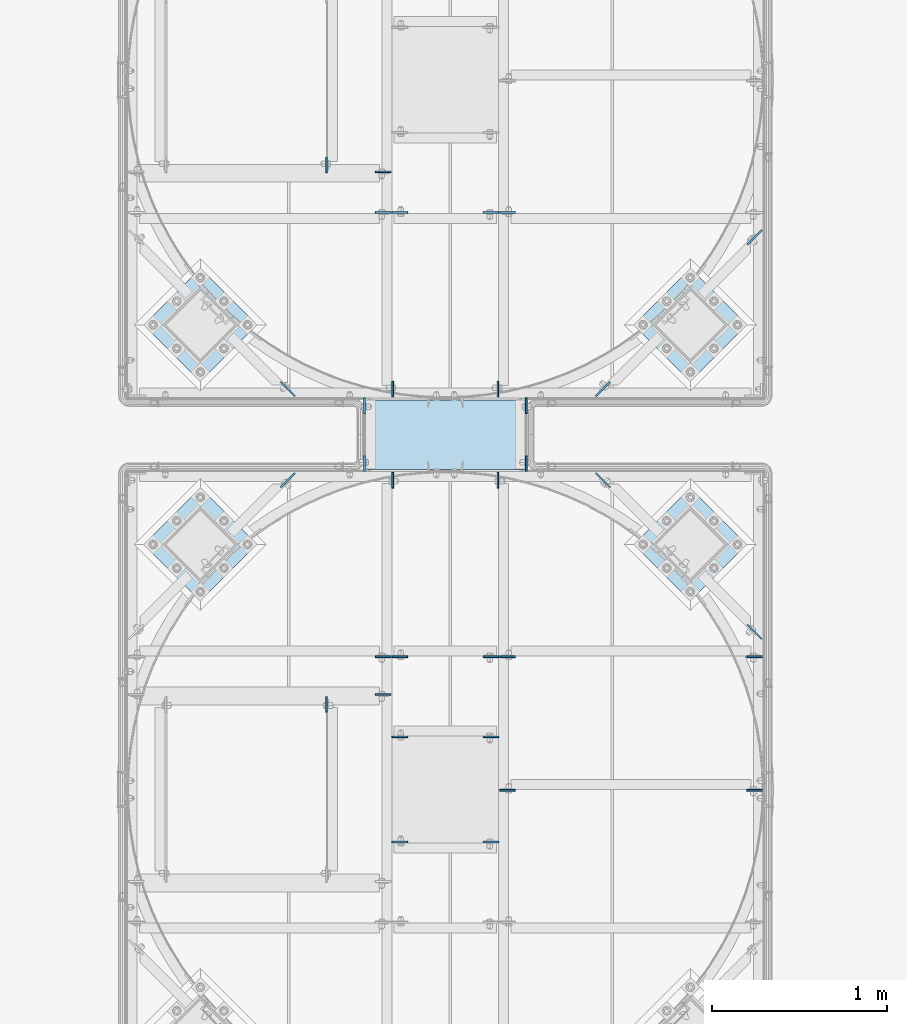
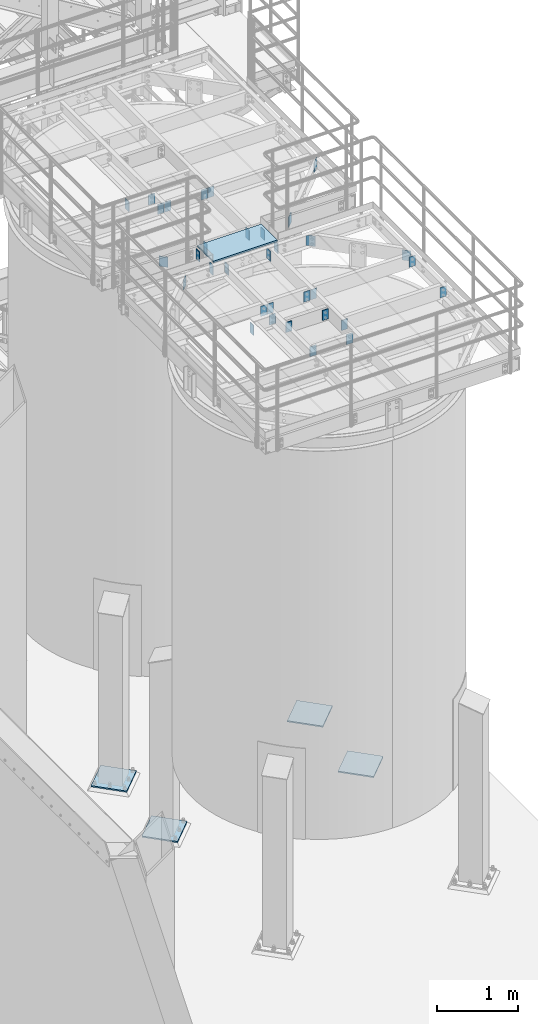
# One storey, part 1417 of 1876: 38 plates, 15 elements without a shape of their own.
"""IFC2X3 building model written with IfcOpenShell, lengths in millimetres."""

from ifc_helpers import new_model, si_unit, frame, origin_with_axes, place, context, subcontext, project, spatial, faceted_brep, material, type_object, element, aggregate, save


model = new_model("IFC2X3")

# Units and contexts
model_context = context("Model", 3, precision=1e-05, world=origin_with_axes())
body_context = subcontext(model_context, "Body", "Model", "MODEL_VIEW")
ifc_project = project(units=[si_unit("LENGTHUNIT", "METRE", prefix="MILLI"), si_unit("AREAUNIT", "SQUARE_METRE"), si_unit("VOLUMEUNIT", "CUBIC_METRE"), si_unit("MASSUNIT", "GRAM", prefix="KILO"), si_unit("TIMEUNIT", "SECOND"), si_unit("PLANEANGLEUNIT", "RADIAN"), si_unit("SOLIDANGLEUNIT", "STERADIAN"), si_unit("THERMODYNAMICTEMPERATUREUNIT", "DEGREE_CELSIUS"), si_unit("LUMINOUSINTENSITYUNIT", "LUMEN")], contexts=[model_context])

# Site, building, storey
site_placement = place(None, origin_with_axes())
site = spatial("IfcSite", under=ifc_project, at=site_placement, CompositionType="ELEMENT")
building_placement = place(site_placement, origin_with_axes())
building = spatial("IfcBuilding", under=site, at=building_placement, Name="Undefined", CompositionType="ELEMENT")
storey_placement = place(building_placement, origin_with_axes())
storey = spatial("IfcBuildingStorey", under=building, at=storey_placement, Name="Undefined", CompositionType="ELEMENT", Elevation=0.0)

# Assembly, plate
assembly_1_placement = place(storey_placement, origin_with_axes())
assembly_1 = element("IfcElementAssembly", 1, at=assembly_1_placement, inside=storey, Name="GRATING", AssemblyPlace="NOTDEFINED", PredefinedType="NOTDEFINED")
ifc_material_1 = material(Name="1")
plate_type_1 = type_object("IfcPlateType", PredefinedType="NOTDEFINED")
plate_1_placement = place(assembly_1_placement, frame((4730.75143150122, -11364.8204711914, 8010.525), z_axis=(1.0, 0.0, 0.0), x_axis=(0.0, -1.0, 0.0)))
plate_1 = element("IfcPlate", 2, at=plate_1_placement, type_object=plate_type_1, material=ifc_material_1, Name="GRATING", context=body_context, shape_type="Brep", body=[
    faceted_brep([(0.0, -12.6999999999998, 0.0), (1.80338247446343e-06, -12.6999999999998, 909.637512207031), (1.80338247446343e-06, 12.6999999999998, 909.637512207031), (0.0, 12.6999999999998, 0.0), (396.931427001953, -12.6999999999998, 909.637512207031), (396.931427001953, 12.6999999999998, 909.637512207031), (396.8720703125, -12.6999999999998, 0.0), (396.8720703125, 12.6999999999998, 0.0)], [[[0, 1, 2, 3]], [[1, 4, 5, 2]], [[4, 6, 7, 5]], [[6, 0, 3, 7]], [[5, 7, 3, 2]], [[6, 4, 1, 0]]]),
])
aggregate(assembly_1, [plate_1])

# Assembly, plates
assembly_2_placement = place(storey_placement, origin_with_axes())
assembly_2 = element("IfcElementAssembly", 3, at=assembly_2_placement, inside=storey, Name="BEAM", AssemblyPlace="NOTDEFINED", PredefinedType="RIGID_FRAME")
ifc_material_2 = material(Name="STEEL/A36")
plate_type_2 = type_object("IfcPlateType", PredefinedType="NOTDEFINED")
plate_2_placement = place(assembly_2_placement, frame((5643.56393150122, -11772.8644531238, 7972.425), z_axis=(0.0, 1.0, 0.0), x_axis=(0.0, 0.0, -1.0)))
plate_2 = element("IfcPlate", 4, at=plate_2_placement, type_object=plate_type_2, material=ifc_material_2, Name="PLATE", context=body_context, shape_type="Brep", body=[
    faceted_brep([(0.0, -4.76249999999982, 0.0), (0.0, -4.76249999999982, 88.9000015258789), (0.0, 4.76249999999982, 88.9000015258789), (0.0, 4.76249999999982, 0.0), (152.399993896484, -4.76249999999982, 88.9000015258789), (152.399993896484, 4.76249999999982, 88.9000015258789), (152.399993896484, -4.76249999999982, 0.0), (152.399993896484, 4.76249999999982, 0.0)], [[[0, 1, 2, 3]], [[1, 4, 5, 2]], [[4, 6, 7, 5]], [[6, 0, 3, 7]], [[5, 7, 3, 2]], [[6, 4, 1, 0]]]),
])
plate_3_placement = place(assembly_2_placement, frame((4719.63893150122, -11772.8644531238, 7972.425), z_axis=(0.0, 1.0, 0.0), x_axis=(0.0, 0.0, -1.0)))
plate_3 = element("IfcPlate", 5, at=plate_3_placement, type_object=plate_type_2, material=ifc_material_2, Name="PLATE", context=body_context, shape_type="Brep", body=[
    faceted_brep([(0.0, -4.76249999999982, 0.0), (0.0, -4.76249999999982, 88.9000015258789), (0.0, 4.76249999999982, 88.9000015258789), (0.0, 4.76249999999982, 0.0), (152.399993896484, -4.76249999999982, 88.9000015258789), (152.399993896484, 4.76249999999982, 88.9000015258789), (152.399993896484, -4.76249999999982, 0.0), (152.399993896484, 4.76249999999982, 0.0)], [[[0, 1, 2, 3]], [[1, 4, 5, 2]], [[4, 6, 7, 5]], [[6, 0, 3, 7]], [[5, 7, 3, 2]], [[6, 4, 1, 0]]]),
])

assembly_3_placement = place(storey_placement, origin_with_axes())
assembly_3 = element("IfcElementAssembly", 6, at=assembly_3_placement, inside=storey, Name="BEAM", AssemblyPlace="NOTDEFINED", PredefinedType="RIGID_FRAME")
plate_4_placement = place(assembly_3_placement, frame((4719.63893150122, -11353.7643554687, 7972.425), z_axis=(0.0, -1.0, 0.0), x_axis=(0.0, 0.0, -1.0)))
plate_4 = element("IfcPlate", 7, at=plate_4_placement, type_object=plate_type_2, material=ifc_material_2, Name="PLATE", context=body_context, shape_type="Brep", body=[
    faceted_brep([(0.0, -4.76249999999982, 0.0), (0.0, -4.76249999999982, 88.9000015258789), (0.0, 4.76249999999982, 88.9000015258789), (0.0, 4.76249999999982, 0.0), (152.399993896484, -4.76249999999982, 88.9000015258789), (152.399993896484, 4.76249999999982, 88.9000015258789), (152.399993896484, -4.76249999999982, 0.0), (152.399993896484, 4.76249999999982, 0.0)], [[[0, 1, 2, 3]], [[1, 4, 5, 2]], [[4, 6, 7, 5]], [[6, 0, 3, 7]], [[5, 7, 3, 2]], [[6, 4, 1, 0]]]),
])
plate_5_placement = place(assembly_3_placement, frame((5643.56393150122, -11353.7643554687, 7972.425), z_axis=(0.0, -1.0, 0.0), x_axis=(0.0, 0.0, -1.0)))
plate_5 = element("IfcPlate", 8, at=plate_5_placement, type_object=plate_type_2, material=ifc_material_2, Name="PLATE", context=body_context, shape_type="Brep", body=[
    faceted_brep([(0.0, -4.76249999999982, 0.0), (0.0, -4.76249999999982, 88.9000015258789), (0.0, 4.76249999999982, 88.9000015258789), (0.0, 4.76249999999982, 0.0), (152.399993896484, -4.76249999999982, 88.9000015258789), (152.399993896484, 4.76249999999982, 88.9000015258789), (152.399993896484, -4.76249999999982, 0.0), (152.399993896484, 4.76249999999982, 0.0)], [[[0, 1, 2, 3]], [[1, 4, 5, 2]], [[4, 6, 7, 5]], [[6, 0, 3, 7]], [[5, 7, 3, 2]], [[6, 4, 1, 0]]]),
])

assembly_4_placement = place(storey_placement, origin_with_axes())
assembly_4 = element("IfcElementAssembly", 9, at=assembly_4_placement, inside=storey, Name="BEAM", AssemblyPlace="NOTDEFINED", PredefinedType="RIGID_FRAME")
plate_6_placement = place(assembly_4_placement, frame((5492.75333884985, -10294.9018554687, 7972.425), z_axis=(1.0, 0.0, 0.0), x_axis=(0.0, 0.0, -1.0)))
plate_6 = element("IfcPlate", 10, at=plate_6_placement, type_object=plate_type_2, material=ifc_material_2, Name="PLATE", context=body_context, shape_type="Brep", body=[
    faceted_brep([(0.0, -4.76249999999982, 0.0), (0.0, -4.76249999999982, 88.9000015258789), (0.0, 4.76249999999982, 88.9000015258789), (0.0, 4.76249999999982, 0.0), (152.399993896484, -4.76249999999982, 88.9000015258789), (152.399993896484, 4.76249999999982, 88.9000015258789), (152.399993896484, -4.76249999999982, 0.0), (152.399993896484, 4.76249999999982, 0.0)], [[[0, 1, 2, 3]], [[1, 4, 5, 2]], [[4, 6, 7, 5]], [[6, 0, 3, 7]], [[5, 7, 3, 2]], [[6, 4, 1, 0]]]),
])
plate_7_placement = place(assembly_4_placement, frame((5486.40333884985, -10294.9018554687, 7972.425), z_axis=(-1.0, 0.0, 0.0), x_axis=(0.0, 0.0, -1.0)))
plate_7 = element("IfcPlate", 11, at=plate_7_placement, type_object=plate_type_2, material=ifc_material_2, Name="PLATE", context=body_context, shape_type="Brep", body=[
    faceted_brep([(0.0, -4.76249999999982, 0.0), (0.0, -4.76249999999982, 88.9000015258789), (0.0, 4.76249999999982, 88.9000015258789), (0.0, 4.76249999999982, 0.0), (152.399993896484, -4.76249999999982, 88.9000015258789), (152.399993896484, 4.76249999999982, 88.9000015258789), (152.399993896484, -4.76249999999982, 0.0), (152.399993896484, 4.76249999999982, 0.0)], [[[0, 1, 2, 3]], [[1, 4, 5, 2]], [[4, 6, 7, 5]], [[6, 0, 3, 7]], [[5, 7, 3, 2]], [[6, 4, 1, 0]]]),
])
aggregate(assembly_4, [plate_6, plate_7])

# Assembly, plate
assembly_5_placement = place(storey_placement, origin_with_axes())
assembly_5 = element("IfcElementAssembly", 12, at=assembly_5_placement, inside=storey, Name="BEAM", AssemblyPlace="NOTDEFINED", PredefinedType="RIGID_FRAME")
plate_8_placement = place(assembly_5_placement, frame((4503.74083884985, -10067.8893554687, 7972.425), z_axis=(0.0, 1.0, 0.0), x_axis=(0.0, 0.0, -1.0)))
plate_8 = element("IfcPlate", 13, at=plate_8_placement, type_object=plate_type_2, material=ifc_material_2, Name="PLATE", context=body_context, shape_type="Brep", body=[
    faceted_brep([(0.0, -4.76249999999982, 0.0), (0.0, -4.76249999999982, 88.9000015258789), (0.0, 4.76249999999982, 88.9000015258789), (0.0, 4.76249999999982, 0.0), (152.399993896484, -4.76249999999982, 88.9000015258789), (152.399993896484, 4.76249999999982, 88.9000015258789), (152.399993896484, -4.76249999999982, 0.0), (152.399993896484, 4.76249999999982, 0.0)], [[[0, 1, 2, 3]], [[1, 4, 5, 2]], [[4, 6, 7, 5]], [[6, 0, 3, 7]], [[5, 7, 3, 2]], [[6, 4, 1, 0]]]),
])
aggregate(assembly_5, [plate_8])

# Assembly, plates
assembly_6_placement = place(storey_placement, origin_with_axes())
assembly_6 = element("IfcElementAssembly", 14, at=assembly_6_placement, inside=storey, Name="BEAM", AssemblyPlace="NOTDEFINED", PredefinedType="RIGID_FRAME")
plate_9_placement = place(assembly_6_placement, frame((4870.45333884985, -10063.1268554687, 7972.425), z_axis=(-1.0, 0.0, 0.0), x_axis=(0.0, 0.0, -1.0)))
plate_9 = element("IfcPlate", 15, at=plate_9_placement, type_object=plate_type_2, material=ifc_material_2, Name="PLATE", context=body_context, shape_type="Brep", body=[
    faceted_brep([(0.0, -4.76249999999982, 0.0), (0.0, -4.76249999999982, 88.9000015258789), (0.0, 4.76249999999982, 88.9000015258789), (0.0, 4.76249999999982, 0.0), (152.399993896484, -4.76249999999982, 88.9000015258789), (152.399993896484, 4.76249999999982, 88.9000015258789), (152.399993896484, -4.76249999999982, 0.0), (152.399993896484, 4.76249999999982, 0.0)], [[[0, 1, 2, 3]], [[1, 4, 5, 2]], [[4, 6, 7, 5]], [[6, 0, 3, 7]], [[5, 7, 3, 2]], [[6, 4, 1, 0]]]),
])
plate_10_placement = place(assembly_6_placement, frame((4870.45333884985, -10294.9018554687, 7972.425), z_axis=(-1.0, 0.0, 0.0), x_axis=(0.0, 0.0, -1.0)))
plate_10 = element("IfcPlate", 16, at=plate_10_placement, type_object=plate_type_2, material=ifc_material_2, Name="PLATE", context=body_context, shape_type="Brep", body=[
    faceted_brep([(0.0, -4.76249999999982, 0.0), (0.0, -4.76249999999982, 88.9000015258789), (0.0, 4.76249999999982, 88.9000015258789), (0.0, 4.76249999999982, 0.0), (152.399993896484, -4.76249999999982, 88.9000015258789), (152.399993896484, 4.76249999999982, 88.9000015258789), (152.399993896484, -4.76249999999982, 0.0), (152.399993896484, 4.76249999999982, 0.0)], [[[0, 1, 2, 3]], [[1, 4, 5, 2]], [[4, 6, 7, 5]], [[6, 0, 3, 7]], [[5, 7, 3, 2]], [[6, 4, 1, 0]]]),
])
plate_11_placement = place(assembly_6_placement, frame((4876.80333884985, -10294.9018554687, 7972.425), z_axis=(1.0, 0.0, 0.0), x_axis=(0.0, 0.0, -1.0)))
plate_11 = element("IfcPlate", 17, at=plate_11_placement, type_object=plate_type_2, material=ifc_material_2, Name="PLATE", context=body_context, shape_type="Brep", body=[
    faceted_brep([(0.0, -4.76249999999982, 0.0), (0.0, -4.76249999999982, 88.9000015258789), (0.0, 4.76249999999982, 88.9000015258789), (0.0, 4.76249999999982, 0.0), (152.399993896484, -4.76249999999982, 88.9000015258789), (152.399993896484, 4.76249999999982, 88.9000015258789), (152.399993896484, -4.76249999999982, 0.0), (152.399993896484, 4.76249999999982, 0.0)], [[[0, 1, 2, 3]], [[1, 4, 5, 2]], [[4, 6, 7, 5]], [[6, 0, 3, 7]], [[5, 7, 3, 2]], [[6, 4, 1, 0]]]),
])
aggregate(assembly_6, [plate_9, plate_10, plate_11])

# Plate
plate_12_placement = place(assembly_3_placement, frame((4881.56583884985, -11347.4143554687, 7972.425), z_axis=(0.0, 1.0, 0.0), x_axis=(0.0, 0.0, -1.0)))
plate_12 = element("IfcPlate", 18, at=plate_12_placement, type_object=plate_type_2, material=ifc_material_2, Name="PLATE", context=body_context, shape_type="Brep", body=[
    faceted_brep([(0.0, -4.76249999999982, 0.0), (0.0, -4.76249999999982, 88.9000015258789), (0.0, 4.76249999999982, 88.9000015258789), (0.0, 4.76249999999982, 0.0), (152.399993896484, -4.76249999999982, 88.9000015258789), (152.399993896484, 4.76249999999982, 88.9000015258789), (152.399993896484, -4.76249999999982, 0.0), (152.399993896484, 4.76249999999982, 0.0)], [[[0, 1, 2, 3]], [[1, 4, 5, 2]], [[4, 6, 7, 5]], [[6, 0, 3, 7]], [[5, 7, 3, 2]], [[6, 4, 1, 0]]]),
])

plate_13_placement = place(assembly_3_placement, frame((5481.64083884985, -11347.4143554687, 7972.425), z_axis=(0.0, 1.0, 0.0), x_axis=(0.0, 0.0, -1.0)))
plate_13 = element("IfcPlate", 19, at=plate_13_placement, type_object=plate_type_2, material=ifc_material_2, Name="PLATE", context=body_context, shape_type="Brep", body=[
    faceted_brep([(0.0, -4.76249999999982, 0.0), (0.0, -4.76249999999982, 88.9000015258789), (0.0, 4.76249999999982, 88.9000015258789), (0.0, 4.76249999999982, 0.0), (152.399993896484, -4.76249999999982, 88.9000015258789), (152.399993896484, 4.76249999999982, 88.9000015258789), (152.399993896484, -4.76249999999982, 0.0), (152.399993896484, 4.76249999999982, 0.0)], [[[0, 1, 2, 3]], [[1, 4, 5, 2]], [[4, 6, 7, 5]], [[6, 0, 3, 7]], [[5, 7, 3, 2]], [[6, 4, 1, 0]]]),
])

plate_14_placement = place(assembly_2_placement, frame((4881.56393150122, -11779.2144531238, 7972.425), z_axis=(0.0, -1.0, 0.0), x_axis=(0.0, 0.0, -1.0)))
plate_14 = element("IfcPlate", 20, at=plate_14_placement, type_object=plate_type_2, material=ifc_material_2, Name="PLATE", context=body_context, shape_type="Brep", body=[
    faceted_brep([(0.0, -4.76249999999982, 0.0), (0.0, -4.76249999999982, 88.9000015258789), (0.0, 4.76249999999982, 88.9000015258789), (0.0, 4.76249999999982, 0.0), (152.399993896484, -4.76249999999982, 88.9000015258789), (152.399993896484, 4.76249999999982, 88.9000015258789), (152.399993896484, -4.76249999999982, 0.0), (152.399993896484, 4.76249999999982, 0.0)], [[[0, 1, 2, 3]], [[1, 4, 5, 2]], [[4, 6, 7, 5]], [[6, 0, 3, 7]], [[5, 7, 3, 2]], [[6, 4, 1, 0]]]),
])

plate_15_placement = place(assembly_2_placement, frame((5481.63893150122, -11779.2144531238, 7972.425), z_axis=(0.0, -1.0, 0.0), x_axis=(0.0, 0.0, -1.0)))
plate_15 = element("IfcPlate", 21, at=plate_15_placement, type_object=plate_type_2, material=ifc_material_2, Name="PLATE", context=body_context, shape_type="Brep", body=[
    faceted_brep([(0.0, -4.76249999999982, 0.0), (0.0, -4.76249999999982, 88.9000015258789), (0.0, 4.76249999999982, 88.9000015258789), (0.0, 4.76249999999982, 0.0), (152.399993896484, -4.76249999999982, 88.9000015258789), (152.399993896484, 4.76249999999982, 88.9000015258789), (152.399993896484, -4.76249999999982, 0.0), (152.399993896484, 4.76249999999982, 0.0)], [[[0, 1, 2, 3]], [[1, 4, 5, 2]], [[4, 6, 7, 5]], [[6, 0, 3, 7]], [[5, 7, 3, 2]], [[6, 4, 1, 0]]]),
])

# Assembly, plate
assembly_7_placement = place(storey_placement, origin_with_axes())
assembly_7 = element("IfcElementAssembly", 22, at=assembly_7_placement, inside=storey, Name="BEAM", AssemblyPlace="NOTDEFINED", PredefinedType="RIGID_FRAME")
plate_16_placement = place(assembly_7_placement, frame((4870.45143150122, -13047.6269042969, 7972.425), z_axis=(-1.0, 0.0, 0.0), x_axis=(0.0, 0.0, -1.0)))
plate_16 = element("IfcPlate", 23, at=plate_16_placement, type_object=plate_type_2, material=ifc_material_2, Name="PLATE", context=body_context, shape_type="Brep", body=[
    faceted_brep([(0.0, -4.76249999999982, 0.0), (0.0, -4.76249999999982, 88.9000015258789), (0.0, 4.76249999999982, 88.9000015258789), (0.0, 4.76249999999982, 0.0), (152.399993896484, -4.76249999999982, 88.9000015258789), (152.399993896484, 4.76249999999982, 88.9000015258789), (152.399993896484, -4.76249999999982, 0.0), (152.399993896484, 4.76249999999982, 0.0)], [[[0, 1, 2, 3]], [[1, 4, 5, 2]], [[4, 6, 7, 5]], [[6, 0, 3, 7]], [[5, 7, 3, 2]], [[6, 4, 1, 0]]]),
])

assembly_8_placement = place(storey_placement, origin_with_axes())
assembly_8 = element("IfcElementAssembly", 24, at=assembly_8_placement, inside=storey, Name="BEAM", AssemblyPlace="NOTDEFINED", PredefinedType="RIGID_FRAME")
plate_17_placement = place(assembly_8_placement, frame((4503.73893150122, -13058.7394042969, 7972.425), z_axis=(0.0, -1.0, 0.0), x_axis=(0.0, 0.0, -1.0)))
plate_17 = element("IfcPlate", 25, at=plate_17_placement, type_object=plate_type_2, material=ifc_material_2, Name="PLATE", context=body_context, shape_type="Brep", body=[
    faceted_brep([(0.0, -4.76249999999982, 0.0), (0.0, -4.76249999999982, 88.9000015258789), (0.0, 4.76249999999982, 88.9000015258789), (0.0, 4.76249999999982, 0.0), (152.399993896484, -4.76249999999982, 88.9000015258789), (152.399993896484, 4.76249999999982, 88.9000015258789), (152.399993896484, -4.76249999999982, 0.0), (152.399993896484, 4.76249999999982, 0.0)], [[[0, 1, 2, 3]], [[1, 4, 5, 2]], [[4, 6, 7, 5]], [[6, 0, 3, 7]], [[5, 7, 3, 2]], [[6, 4, 1, 0]]]),
])
aggregate(assembly_8, [plate_17])

assembly_9_placement = place(storey_placement, origin_with_axes())
assembly_9 = element("IfcElementAssembly", 26, at=assembly_9_placement, inside=storey, Name="BEAM", AssemblyPlace="NOTDEFINED", PredefinedType="RIGID_FRAME")
plate_18_placement = place(assembly_9_placement, frame((6991.34856849878, -13593.7269287103, 7972.425), z_axis=(-1.0, 0.0, 0.0), x_axis=(0.0, 0.0, -1.0)))
plate_18 = element("IfcPlate", 27, at=plate_18_placement, type_object=plate_type_2, material=ifc_material_2, Name="PLATE", context=body_context, shape_type="Brep", body=[
    faceted_brep([(0.0, -4.76249999999982, 0.0), (0.0, -4.76249999999982, 88.9000015258789), (0.0, 4.76249999999982, 88.9000015258789), (0.0, 4.76249999999982, 0.0), (152.399993896484, -4.76249999999982, 88.9000015258789), (152.399993896484, 4.76249999999982, 88.9000015258789), (152.399993896484, -4.76249999999982, 0.0), (152.399993896484, 4.76249999999982, 0.0)], [[[0, 1, 2, 3]], [[1, 4, 5, 2]], [[4, 6, 7, 5]], [[6, 0, 3, 7]], [[5, 7, 3, 2]], [[6, 4, 1, 0]]]),
])

assembly_10_placement = place(storey_placement, origin_with_axes())
assembly_10 = element("IfcElementAssembly", 28, at=assembly_10_placement, inside=storey, Name="BEAM", AssemblyPlace="NOTDEFINED", PredefinedType="RIGID_FRAME")
plate_19_placement = place(assembly_10_placement, frame((5492.75143150122, -13593.7269287103, 7972.42499999999), z_axis=(1.0, 0.0, 0.0), x_axis=(0.0, 0.0, -1.0)))
plate_19 = element("IfcPlate", 29, at=plate_19_placement, type_object=plate_type_2, material=ifc_material_2, Name="PLATE", context=body_context, shape_type="Brep", body=[
    faceted_brep([(0.0, -4.76249999999982, 0.0), (0.0, -4.76249999999982, 88.9000015258789), (0.0, 4.76249999999982, 88.9000015258789), (0.0, 4.76249999999982, 0.0), (152.399993896484, -4.76249999999982, 88.9000015258789), (152.399993896484, 4.76249999999982, 88.9000015258789), (152.399993896484, -4.76249999999982, 0.0), (152.399993896484, 4.76249999999982, 0.0)], [[[0, 1, 2, 3]], [[1, 4, 5, 2]], [[4, 6, 7, 5]], [[6, 0, 3, 7]], [[5, 7, 3, 2]], [[6, 4, 1, 0]]]),
])

# Plate
plate_20_placement = place(assembly_7_placement, frame((4870.45143150122, -12831.7269042969, 7972.425), z_axis=(-1.0, 0.0, 0.0), x_axis=(0.0, 0.0, -1.0)))
plate_20 = element("IfcPlate", 30, at=plate_20_placement, type_object=plate_type_2, material=ifc_material_2, Name="PLATE", context=body_context, shape_type="Brep", body=[
    faceted_brep([(0.0, -4.76249999999982, 0.0), (0.0, -4.76249999999982, 88.9000015258789), (0.0, 4.76249999999982, 88.9000015258789), (0.0, 4.76249999999982, 0.0), (152.399993896484, -4.76249999999982, 88.9000015258789), (152.399993896484, 4.76249999999982, 88.9000015258789), (152.399993896484, -4.76249999999982, 0.0), (152.399993896484, 4.76249999999982, 0.0)], [[[0, 1, 2, 3]], [[1, 4, 5, 2]], [[4, 6, 7, 5]], [[6, 0, 3, 7]], [[5, 7, 3, 2]], [[6, 4, 1, 0]]]),
])

plate_21_placement = place(assembly_9_placement, frame((6991.34856849878, -12831.7269042969, 7972.425), z_axis=(-1.0, 0.0, 0.0), x_axis=(0.0, 0.0, -1.0)))
plate_21 = element("IfcPlate", 31, at=plate_21_placement, type_object=plate_type_2, material=ifc_material_2, Name="PLATE", context=body_context, shape_type="Brep", body=[
    faceted_brep([(0.0, -4.76249999999982, 0.0), (0.0, -4.76249999999982, 88.9000015258789), (0.0, 4.76249999999982, 88.9000015258789), (0.0, 4.76249999999982, 0.0), (152.399993896484, -4.76249999999982, 88.9000015258789), (152.399993896484, 4.76249999999982, 88.9000015258789), (152.399993896484, -4.76249999999982, 0.0), (152.399993896484, 4.76249999999982, 0.0)], [[[0, 1, 2, 3]], [[1, 4, 5, 2]], [[4, 6, 7, 5]], [[6, 0, 3, 7]], [[5, 7, 3, 2]], [[6, 4, 1, 0]]]),
])

plate_22_placement = place(assembly_10_placement, frame((5492.75143150122, -12831.7269042969, 7972.425), z_axis=(1.0, 0.0, 0.0), x_axis=(0.0, 0.0, -1.0)))
plate_22 = element("IfcPlate", 32, at=plate_22_placement, type_object=plate_type_2, material=ifc_material_2, Name="PLATE", context=body_context, shape_type="Brep", body=[
    faceted_brep([(0.0, -4.76249999999982, 0.0), (0.0, -4.76249999999982, 88.9000015258789), (0.0, 4.76249999999982, 88.9000015258789), (0.0, 4.76249999999982, 0.0), (152.399993896484, -4.76249999999982, 88.9000015258789), (152.399993896484, 4.76249999999982, 88.9000015258789), (152.399993896484, -4.76249999999982, 0.0), (152.399993896484, 4.76249999999982, 0.0)], [[[0, 1, 2, 3]], [[1, 4, 5, 2]], [[4, 6, 7, 5]], [[6, 0, 3, 7]], [[5, 7, 3, 2]], [[6, 4, 1, 0]]]),
])

plate_23_placement = place(assembly_7_placement, frame((4876.80143150122, -12831.7269042969, 7972.425), z_axis=(1.0, 0.0, 0.0), x_axis=(0.0, 0.0, -1.0)))
plate_23 = element("IfcPlate", 33, at=plate_23_placement, type_object=plate_type_2, material=ifc_material_2, Name="PLATE", context=body_context, shape_type="Brep", body=[
    faceted_brep([(0.0, -4.76249999999982, 0.0), (0.0, -4.76249999999982, 88.9000015258789), (0.0, 4.76249999999982, 88.9000015258789), (0.0, 4.76249999999982, 0.0), (152.399993896484, -4.76249999999982, 88.9000015258789), (152.399993896484, 4.76249999999982, 88.9000015258789), (152.399993896484, -4.76249999999982, 0.0), (152.399993896484, 4.76249999999982, 0.0)], [[[0, 1, 2, 3]], [[1, 4, 5, 2]], [[4, 6, 7, 5]], [[6, 0, 3, 7]], [[5, 7, 3, 2]], [[6, 4, 1, 0]]]),
])

plate_24_placement = place(assembly_10_placement, frame((5486.40143150122, -12831.7269042969, 7972.425), z_axis=(-1.0, 0.0, 0.0), x_axis=(0.0, 0.0, -1.0)))
plate_24 = element("IfcPlate", 34, at=plate_24_placement, type_object=plate_type_2, material=ifc_material_2, Name="PLATE", context=body_context, shape_type="Brep", body=[
    faceted_brep([(0.0, -4.76249999999982, 0.0), (0.0, -4.76249999999982, 88.9000015258789), (0.0, 4.76249999999982, 88.9000015258789), (0.0, 4.76249999999982, 0.0), (152.399993896484, -4.76249999999982, 88.9000015258789), (152.399993896484, 4.76249999999982, 88.9000015258789), (152.399993896484, -4.76249999999982, 0.0), (152.399993896484, 4.76249999999982, 0.0)], [[[0, 1, 2, 3]], [[1, 4, 5, 2]], [[4, 6, 7, 5]], [[6, 0, 3, 7]], [[5, 7, 3, 2]], [[6, 4, 1, 0]]]),
])

plate_25_placement = place(assembly_7_placement, frame((4876.80143150122, -13288.9269287103, 7972.425), z_axis=(1.0, 0.0, 0.0), x_axis=(0.0, 0.0, -1.0)))
plate_25 = element("IfcPlate", 35, at=plate_25_placement, type_object=plate_type_2, material=ifc_material_2, Name="PLATE", context=body_context, shape_type="Brep", body=[
    faceted_brep([(0.0, -4.76249999999982, 0.0), (0.0, -4.76249999999982, 88.9000015258789), (0.0, 4.76249999999982, 88.9000015258789), (0.0, 4.76249999999982, 0.0), (152.399993896484, -4.76249999999982, 88.9000015258789), (152.399993896484, 4.76249999999982, 88.9000015258789), (152.399993896484, -4.76249999999982, 0.0), (152.399993896484, 4.76249999999982, 0.0)], [[[0, 1, 2, 3]], [[1, 4, 5, 2]], [[4, 6, 7, 5]], [[6, 0, 3, 7]], [[5, 7, 3, 2]], [[6, 4, 1, 0]]]),
])

plate_26_placement = place(assembly_10_placement, frame((5486.40143150122, -13288.9269287103, 7972.425), z_axis=(-1.0, 0.0, 0.0), x_axis=(0.0, 0.0, -1.0)))
plate_26 = element("IfcPlate", 36, at=plate_26_placement, type_object=plate_type_2, material=ifc_material_2, Name="PLATE", context=body_context, shape_type="Brep", body=[
    faceted_brep([(0.0, -4.76249999999982, 0.0), (0.0, -4.76249999999982, 88.9000015258789), (0.0, 4.76249999999982, 88.9000015258789), (0.0, 4.76249999999982, 0.0), (152.399993896484, -4.76249999999982, 88.9000015258789), (152.399993896484, 4.76249999999982, 88.9000015258789), (152.399993896484, -4.76249999999982, 0.0), (152.399993896484, 4.76249999999982, 0.0)], [[[0, 1, 2, 3]], [[1, 4, 5, 2]], [[4, 6, 7, 5]], [[6, 0, 3, 7]], [[5, 7, 3, 2]], [[6, 4, 1, 0]]]),
])

plate_27_placement = place(assembly_10_placement, frame((5486.40143150122, -13889.0019287103, 7972.425), z_axis=(-1.0, 0.0, 0.0), x_axis=(0.0, 0.0, -1.0)))
plate_27 = element("IfcPlate", 37, at=plate_27_placement, type_object=plate_type_2, material=ifc_material_2, Name="PLATE", context=body_context, shape_type="Brep", body=[
    faceted_brep([(0.0, -4.76249999999982, 0.0), (0.0, -4.76249999999982, 88.9000015258789), (0.0, 4.76249999999982, 88.9000015258789), (0.0, 4.76249999999982, 0.0), (152.399993896484, -4.76249999999982, 88.9000015258789), (152.399993896484, 4.76249999999982, 88.9000015258789), (152.399993896484, -4.76249999999982, 0.0), (152.399993896484, 4.76249999999982, 0.0)], [[[0, 1, 2, 3]], [[1, 4, 5, 2]], [[4, 6, 7, 5]], [[6, 0, 3, 7]], [[5, 7, 3, 2]], [[6, 4, 1, 0]]]),
])

aggregate(assembly_10, [plate_19, plate_22, plate_24, plate_26, plate_27])

plate_28_placement = place(assembly_7_placement, frame((4876.80143150122, -13889.0019287103, 7972.425), z_axis=(1.0, 0.0, 0.0), x_axis=(0.0, 0.0, -1.0)))
plate_28 = element("IfcPlate", 38, at=plate_28_placement, type_object=plate_type_2, material=ifc_material_2, Name="PLATE", context=body_context, shape_type="Brep", body=[
    faceted_brep([(0.0, -4.76249999999982, 0.0), (0.0, -4.76249999999982, 88.9000015258789), (0.0, 4.76249999999982, 88.9000015258789), (0.0, 4.76249999999982, 0.0), (152.399993896484, -4.76249999999982, 88.9000015258789), (152.399993896484, 4.76249999999982, 88.9000015258789), (152.399993896484, -4.76249999999982, 0.0), (152.399993896484, 4.76249999999982, 0.0)], [[[0, 1, 2, 3]], [[1, 4, 5, 2]], [[4, 6, 7, 5]], [[6, 0, 3, 7]], [[5, 7, 3, 2]], [[6, 4, 1, 0]]]),
])

aggregate(assembly_7, [plate_16, plate_20, plate_23, plate_25, plate_28])

# Assembly, plate
assembly_11_placement = place(storey_placement, origin_with_axes())
assembly_11 = element("IfcElementAssembly", 39, at=assembly_11_placement, inside=storey, Name="BEAM", AssemblyPlace="NOTDEFINED", PredefinedType="RIGID_FRAME")
plate_type_3 = type_object("IfcPlateType", PredefinedType="NOTDEFINED")
plate_29_placement = place(assembly_11_placement, frame((6987.98287980201, -10396.1380257263, 7972.425), z_axis=(-0.707106781186547, -0.707106781186548, 0.0), x_axis=(0.0, 0.0, -1.0)))
plate_29 = element("IfcPlate", 40, at=plate_29_placement, type_object=plate_type_3, material=ifc_material_2, Name="PLATE", context=body_context, shape_type="Brep", body=[
    faceted_brep([(0.0, -4.76249999999982, 0.0), (0.0, -4.76249999999891, 116.385513305684), (0.0, 4.76250000000255, 116.385513305684), (0.0, 4.76249999999982, 0.0), (152.399993896484, -4.76249999999891, 116.385513305684), (152.399993896484, 4.76250000000255, 116.385513305684), (152.399993896484, -4.76249999999982, 0.0), (152.399993896484, 4.76249999999982, 0.0)], [[[0, 1, 2, 3]], [[1, 4, 5, 2]], [[4, 6, 7, 5]], [[6, 0, 3, 7]], [[5, 7, 3, 2]], [[6, 4, 1, 0]]]),
])
aggregate(assembly_11, [plate_29])

# Plate
plate_30_placement = place(assembly_3_placement, frame((4323.12966859229, -11344.0467594233, 7972.425), z_axis=(-0.707106781186548, 0.707106781186547, 0.0), x_axis=(0.0, 0.0, -1.0)))
plate_30 = element("IfcPlate", 41, at=plate_30_placement, type_object=plate_type_3, material=ifc_material_2, Name="PLATE", context=body_context, shape_type="Brep", body=[
    faceted_brep([(0.0, -4.76249999999982, 0.0), (0.0, -4.76249999999891, 116.385513305684), (0.0, 4.76250000000255, 116.385513305684), (0.0, 4.76249999999982, 0.0), (152.399993896484, -4.76249999999891, 116.385513305684), (152.399993896484, 4.76250000000255, 116.385513305684), (152.399993896484, -4.76249999999982, 0.0), (152.399993896484, 4.76249999999982, 0.0)], [[[0, 1, 2, 3]], [[1, 4, 5, 2]], [[4, 6, 7, 5]], [[6, 0, 3, 7]], [[5, 7, 3, 2]], [[6, 4, 1, 0]]]),
])

plate_31_placement = place(assembly_3_placement, frame((6040.07414610375, -11344.0467594233, 7972.425), z_axis=(0.707106781186548, 0.707106781186547, 0.0), x_axis=(0.0, 0.0, -1.0)))
plate_31 = element("IfcPlate", 42, at=plate_31_placement, type_object=plate_type_3, material=ifc_material_2, Name="PLATE", context=body_context, shape_type="Brep", body=[
    faceted_brep([(0.0, -4.76249999999982, 0.0), (0.0, -4.76249999999891, 116.385513305684), (0.0, 4.76250000000255, 116.385513305684), (0.0, 4.76249999999982, 0.0), (152.399993896484, -4.76249999999891, 116.385513305684), (152.399993896484, 4.76250000000255, 116.385513305684), (152.399993896484, -4.76249999999982, 0.0), (152.399993896484, 4.76249999999982, 0.0)], [[[0, 1, 2, 3]], [[1, 4, 5, 2]], [[4, 6, 7, 5]], [[6, 0, 3, 7]], [[5, 7, 3, 2]], [[6, 4, 1, 0]]]),
])

aggregate(assembly_3, [plate_4, plate_5, plate_30, plate_31, plate_12, plate_13])

plate_32_placement = place(assembly_2_placement, frame((4323.12776124363, -11782.5820491692, 7972.425), z_axis=(-0.707106781186547, -0.707106781186548, 0.0), x_axis=(0.0, 0.0, -1.0)))
plate_32 = element("IfcPlate", 43, at=plate_32_placement, type_object=plate_type_3, material=ifc_material_2, Name="PLATE", context=body_context, shape_type="Brep", body=[
    faceted_brep([(0.0, -4.76249999999982, 0.0), (0.0, -4.76249999999891, 116.385513305684), (0.0, 4.76250000000255, 116.385513305684), (0.0, 4.76249999999982, 0.0), (152.399993896484, -4.76249999999891, 116.385513305684), (152.399993896484, 4.76250000000255, 116.385513305684), (152.399993896484, -4.76249999999982, 0.0), (152.399993896484, 4.76249999999982, 0.0)], [[[0, 1, 2, 3]], [[1, 4, 5, 2]], [[4, 6, 7, 5]], [[6, 0, 3, 7]], [[5, 7, 3, 2]], [[6, 4, 1, 0]]]),
])

plate_33_placement = place(assembly_9_placement, frame((6987.98097245337, -12730.2923458674, 7972.425), z_axis=(-0.707106781186548, 0.707106781186547, 0.0), x_axis=(0.0, 0.0, -1.0)))
plate_33 = element("IfcPlate", 44, at=plate_33_placement, type_object=plate_type_3, material=ifc_material_2, Name="PLATE", context=body_context, shape_type="Brep", body=[
    faceted_brep([(0.0, -4.76249999999982, 0.0), (0.0, -4.76249999999891, 116.385513305684), (0.0, 4.76250000000255, 116.385513305684), (0.0, 4.76249999999982, 0.0), (152.399993896484, -4.76249999999891, 116.385513305684), (152.399993896484, 4.76250000000255, 116.385513305684), (152.399993896484, -4.76249999999982, 0.0), (152.399993896484, 4.76249999999982, 0.0)], [[[0, 1, 2, 3]], [[1, 4, 5, 2]], [[4, 6, 7, 5]], [[6, 0, 3, 7]], [[5, 7, 3, 2]], [[6, 4, 1, 0]]]),
])

aggregate(assembly_9, [plate_33, plate_18, plate_21])

plate_34_placement = place(assembly_2_placement, frame((6040.27067575514, -11782.5820491692, 7972.425), z_axis=(0.707106781186547, -0.707106781186548, 0.0), x_axis=(0.0, 0.0, -1.0)))
plate_34 = element("IfcPlate", 45, at=plate_34_placement, type_object=plate_type_3, material=ifc_material_2, Name="PLATE", context=body_context, shape_type="Brep", body=[
    faceted_brep([(0.0, -4.76249999999982, 0.0), (0.0, -4.76249999999891, 116.385513305684), (0.0, 4.76250000000255, 116.385513305684), (0.0, 4.76249999999982, 0.0), (152.399993896484, -4.76249999999891, 116.385513305684), (152.399993896484, 4.76250000000255, 116.385513305684), (152.399993896484, -4.76249999999982, 0.0), (152.399993896484, 4.76249999999982, 0.0)], [[[0, 1, 2, 3]], [[1, 4, 5, 2]], [[4, 6, 7, 5]], [[6, 0, 3, 7]], [[5, 7, 3, 2]], [[6, 4, 1, 0]]]),
])

aggregate(assembly_2, [plate_2, plate_3, plate_32, plate_34, plate_14, plate_15])

# Assembly, plate
assembly_12_placement = place(storey_placement, origin_with_axes())
assembly_12 = element("IfcElementAssembly", 46, at=assembly_12_placement, inside=storey, Name="COLUMN", AssemblyPlace="NOTDEFINED", PredefinedType="RIGID_FRAME")
ifc_material_3 = material(Name="STEEL/A572-GR.50")
plate_type_4 = type_object("IfcPlateType", PredefinedType="NOTDEFINED")
plate_35_placement = place(assembly_12_placement, frame((6580.27489085653, -12513.614329502, 47.625), z_axis=(-0.707106781186548, 0.707106781186547, 0.0), x_axis=(0.707106781186548, 0.707106781186547, 0.0)))
plate_35 = element("IfcPlate", 47, at=plate_35_placement, type_object=plate_type_4, material=ifc_material_3, Name="PLATE", context=body_context, shape_type="Brep", body=[
    faceted_brep([(-9.09494701772928e-13, -9.525, -1.81898940354586e-12), (-1.81898940354586e-12, -9.525, 457.200012207104), (-1.81898940354586e-12, 9.525, 457.200012207104), (-9.09494701772928e-13, 9.525, -1.81898940354586e-12), (457.200012207107, -9.525, 457.200012207106), (457.200012207107, 9.525, 457.200012207106), (457.200012207109, -9.525, -1.81898940354586e-12), (457.200012207109, 9.525, -1.81898940354586e-12)], [[[0, 1, 2, 3]], [[1, 4, 5, 2]], [[4, 6, 7, 5]], [[6, 0, 3, 7]], [[5, 7, 3, 2]], [[6, 4, 1, 0]]]),
])
aggregate(assembly_12, [plate_35])

assembly_13_placement = place(storey_placement, origin_with_axes())
assembly_13 = element("IfcElementAssembly", 48, at=assembly_13_placement, inside=storey, Name="COLUMN", AssemblyPlace="NOTDEFINED", PredefinedType="RIGID_FRAME")
plate_36_placement = place(assembly_13_placement, frame((6580.27820529291, -11259.5216107688, 47.625), z_axis=(-0.707106781186548, 0.707106781186547, 0.0), x_axis=(0.707106781186548, 0.707106781186547, 0.0)))
plate_36 = element("IfcPlate", 49, at=plate_36_placement, type_object=plate_type_4, material=ifc_material_3, Name="PLATE", context=body_context, shape_type="Brep", body=[
    faceted_brep([(-9.09494701772928e-13, -9.525, -1.81898940354586e-12), (-1.81898940354586e-12, -9.525, 457.200012207104), (-1.81898940354586e-12, 9.525, 457.200012207104), (-9.09494701772928e-13, 9.525, -1.81898940354586e-12), (457.200012207107, -9.525, 457.200012207106), (457.200012207107, 9.525, 457.200012207106), (457.200012207109, -9.525, -1.81898940354586e-12), (457.200012207109, 9.525, -1.81898940354586e-12)], [[[0, 1, 2, 3]], [[1, 4, 5, 2]], [[4, 6, 7, 5]], [[6, 0, 3, 7]], [[5, 7, 3, 2]], [[6, 4, 1, 0]]]),
])
aggregate(assembly_13, [plate_36])

assembly_14_placement = place(storey_placement, origin_with_axes())
assembly_14 = element("IfcElementAssembly", 50, at=assembly_14_placement, inside=storey, Name="COLUMN", AssemblyPlace="NOTDEFINED", PredefinedType="RIGID_FRAME")
plate_37_placement = place(assembly_14_placement, frame((3782.92548850865, -11259.6670462863, 47.625), z_axis=(-0.707106781186548, 0.707106781186547, 0.0), x_axis=(0.707106781186548, 0.707106781186547, 0.0)))
plate_37 = element("IfcPlate", 51, at=plate_37_placement, type_object=plate_type_4, material=ifc_material_3, Name="PLATE", context=body_context, shape_type="Brep", body=[
    faceted_brep([(-9.09494701772928e-13, -9.525, -1.81898940354586e-12), (-1.81898940354586e-12, -9.525, 457.200012207104), (-1.81898940354586e-12, 9.525, 457.200012207104), (-9.09494701772928e-13, 9.525, -1.81898940354586e-12), (457.200012207107, -9.525, 457.200012207106), (457.200012207107, 9.525, 457.200012207106), (457.200012207109, -9.525, -1.81898940354586e-12), (457.200012207109, 9.525, -1.81898940354586e-12)], [[[0, 1, 2, 3]], [[1, 4, 5, 2]], [[4, 6, 7, 5]], [[6, 0, 3, 7]], [[5, 7, 3, 2]], [[6, 4, 1, 0]]]),
])
aggregate(assembly_14, [plate_37])

assembly_15_placement = place(storey_placement, origin_with_axes())
assembly_15 = element("IfcElementAssembly", 52, at=assembly_15_placement, inside=storey, Name="COLUMN", AssemblyPlace="NOTDEFINED", PredefinedType="RIGID_FRAME")
plate_38_placement = place(assembly_15_placement, frame((3783.01287936518, -12513.5595992774, 47.625), z_axis=(-0.707106781186548, 0.707106781186547, 0.0), x_axis=(0.707106781186548, 0.707106781186547, 0.0)))
plate_38 = element("IfcPlate", 53, at=plate_38_placement, type_object=plate_type_4, material=ifc_material_3, Name="PLATE", context=body_context, shape_type="Brep", body=[
    faceted_brep([(-9.09494701772928e-13, -9.525, -1.81898940354586e-12), (-1.81898940354586e-12, -9.525, 457.200012207104), (-1.81898940354586e-12, 9.525, 457.200012207104), (-9.09494701772928e-13, 9.525, -1.81898940354586e-12), (457.200012207107, -9.525, 457.200012207106), (457.200012207107, 9.525, 457.200012207106), (457.200012207109, -9.525, -1.81898940354586e-12), (457.200012207109, 9.525, -1.81898940354586e-12)], [[[0, 1, 2, 3]], [[1, 4, 5, 2]], [[4, 6, 7, 5]], [[6, 0, 3, 7]], [[5, 7, 3, 2]], [[6, 4, 1, 0]]]),
])
aggregate(assembly_15, [plate_38])

save(model, "model.ifc")
